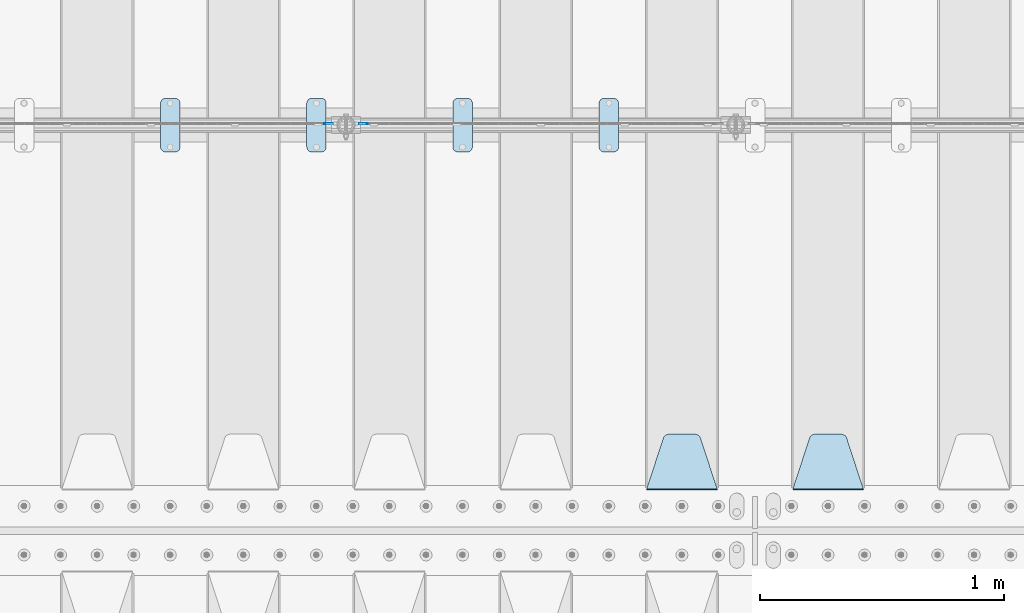
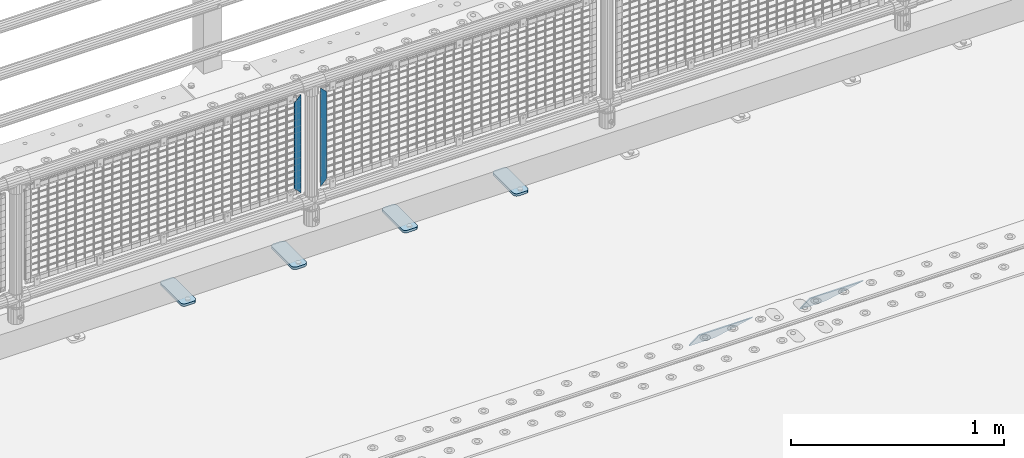
# One storey, part 220 of 257: 8 plates.
"""IFC2X3 building model written with IfcOpenShell, lengths in millimetres."""

from ifc_helpers import new_model, si_unit, frame, origin_with_axes, place, context, subcontext, project, spatial, faceted_brep, material, type_object, element, save


model = new_model("IFC2X3")

# Units and contexts
model_context = context("Model", 3, precision=1e-05, world=origin_with_axes())
body_context = subcontext(model_context, "Body", "Model", "MODEL_VIEW")
ifc_project = project(units=[si_unit("LENGTHUNIT", "METRE", prefix="MILLI"), si_unit("AREAUNIT", "SQUARE_METRE"), si_unit("VOLUMEUNIT", "CUBIC_METRE"), si_unit("MASSUNIT", "GRAM", prefix="KILO"), si_unit("TIMEUNIT", "SECOND"), si_unit("PLANEANGLEUNIT", "RADIAN"), si_unit("SOLIDANGLEUNIT", "STERADIAN"), si_unit("THERMODYNAMICTEMPERATUREUNIT", "DEGREE_CELSIUS"), si_unit("LUMINOUSINTENSITYUNIT", "LUMEN")], contexts=[model_context])

# Site, building, storey
site_placement = place(None, origin_with_axes())
site = spatial("IfcSite", under=ifc_project, at=site_placement, CompositionType="ELEMENT")
building_placement = place(site_placement, origin_with_axes())
building = spatial("IfcBuilding", under=site, at=building_placement, Name="Standard", CompositionType="ELEMENT")
storey_placement = place(building_placement, origin_with_axes())
storey = spatial("IfcBuildingStorey", under=building, at=storey_placement, Name="Undefined", CompositionType="ELEMENT", Elevation=0.0)

# Plates
ifc_material_1 = material(Name="STEEL/S355J2")
plate_type_1 = type_object("IfcPlateType", PredefinedType="NOTDEFINED")
plate_1_placement = place(storey_placement, frame((47310.0, 10774.5, 21.0199999999977), z_axis=(1.0, 0.0, 0.0), x_axis=(0.0, -1.0, 0.0)))
element("IfcPlate", 1, at=plate_1_placement, inside=storey, type_object=plate_type_1, material=ifc_material_1, context=body_context, shape_type="Brep", body=[
    faceted_brep([(0.0, -7.0, 20.0), (0.0, -7.0, 60.0), (0.0, 7.0, 60.0), (0.0, 7.0, 20.0), (0.384294391935327, -7.0, 63.9018064403208), (0.384294391935327, 7.0, 63.9018064403208), (1.52240934977453, -7.0, 67.6536686473046), (1.52240934977453, 7.0, 67.6536686473046), (3.37060775394821, -7.0, 71.1114046603907), (3.37060775394821, 7.0, 71.1114046603907), (5.85786437626848, -7.0, 74.1421356237333), (5.85786437626848, 7.0, 74.1421356237333), (8.88859533960749, -7.0, 76.6293922460536), (8.88859533960749, 7.0, 76.6293922460536), (12.3463313526991, -7.0, 78.4775906502255), (12.3463313526991, 7.0, 78.4775906502255), (16.0981935596774, -7.0, 79.6157056080629), (16.0981935596774, 7.0, 79.6157056080629), (20.0, -7.0, 80.0), (20.0, 7.0, 80.0), (200.0, -7.0, 80.0), (200.0, 7.0, 80.0), (203.901806440323, -7.0, 79.6157056080629), (203.901806440323, 7.0, 79.6157056080629), (207.653668647301, -7.0, 78.4775906502255), (207.653668647301, 7.0, 78.4775906502255), (211.111404660393, -7.0, 76.6293922460536), (211.111404660393, 7.0, 76.6293922460536), (214.142135623732, -7.0, 74.1421356237333), (214.142135623732, 7.0, 74.1421356237333), (216.629392246052, -7.0, 71.1114046603907), (216.629392246052, 7.0, 71.1114046603907), (218.477590650225, -7.0, 67.6536686473046), (218.477590650225, 7.0, 67.6536686473046), (219.615705608065, -7.0, 63.9018064403208), (219.615705608065, 7.0, 63.9018064403208), (220.0, -7.0, 60.0), (220.0, 7.0, 60.0), (220.0, -7.0, 20.0), (220.0, 7.0, 20.0), (219.615705608065, -7.0, 16.0981935596792), (219.615705608065, 7.0, 16.0981935596792), (218.477590650225, -7.0, 12.3463313526954), (218.477590650225, 7.0, 12.3463313526954), (216.629392246052, -7.0, 8.88859533960931), (216.629392246052, 7.0, 8.88859533960931), (214.142135623732, -7.0, 5.85786437626666), (214.142135623732, 7.0, 5.85786437626666), (211.111404660393, -7.0, 3.37060775394639), (211.111404660393, 7.0, 3.37060775394639), (207.653668647301, -7.0, 1.52240934977453), (207.653668647301, 7.0, 1.52240934977453), (203.901806440323, -7.0, 0.384294391937146), (203.901806440323, 7.0, 0.384294391937146), (200.0, -7.0, 0.0), (200.0, 7.0, 0.0), (20.0, -7.0, 0.0), (20.0, 7.0, 0.0), (16.0981935596774, -7.0, 0.384294391937146), (16.0981935596774, 7.0, 0.384294391937146), (12.3463313526991, -7.0, 1.52240934977453), (12.3463313526991, 7.0, 1.52240934977453), (8.88859533960749, -7.0, 3.37060775394639), (8.88859533960749, 7.0, 3.37060775394639), (5.85786437626848, -7.0, 5.85786437626666), (5.85786437626848, 7.0, 5.85786437626666), (3.37060775394821, -7.0, 8.88859533960931), (3.37060775394821, 7.0, 8.88859533960931), (1.52240934977453, -7.0, 12.3463313526954), (1.52240934977453, 7.0, 12.3463313526954), (0.384294391935327, -7.0, 16.0981935596792), (0.384294391935327, 7.0, 16.0981935596792)], [[[0, 1, 2, 3]], [[1, 4, 5, 2]], [[4, 6, 7, 5]], [[6, 8, 9, 7]], [[8, 10, 11, 9]], [[10, 12, 13, 11]], [[12, 14, 15, 13]], [[14, 16, 17, 15]], [[16, 18, 19, 17]], [[18, 20, 21, 19]], [[20, 22, 23, 21]], [[22, 24, 25, 23]], [[24, 26, 27, 25]], [[26, 28, 29, 27]], [[28, 30, 31, 29]], [[30, 32, 33, 31]], [[32, 34, 35, 33]], [[34, 36, 37, 35]], [[36, 38, 39, 37]], [[38, 40, 41, 39]], [[40, 42, 43, 41]], [[42, 44, 45, 43]], [[44, 46, 47, 45]], [[46, 48, 49, 47]], [[48, 50, 51, 49]], [[50, 52, 53, 51]], [[52, 54, 55, 53]], [[54, 56, 57, 55]], [[56, 58, 59, 57]], [[58, 60, 61, 59]], [[60, 62, 63, 61]], [[62, 64, 65, 63]], [[64, 66, 67, 65]], [[66, 68, 69, 67]], [[68, 70, 71, 69]], [[70, 0, 3, 71]], [[5, 7, 9, 11, 13, 15, 17, 19, 21, 23, 25, 27, 29, 31, 33, 35, 37, 39, 41, 43, 45, 47, 49, 51, 53, 55, 57, 59, 61, 63, 65, 67, 69, 71, 3, 2]], [[70, 68, 66, 64, 62, 60, 58, 56, 54, 52, 50, 48, 46, 44, 42, 40, 38, 36, 34, 32, 30, 28, 26, 24, 22, 20, 18, 16, 14, 12, 10, 8, 6, 4, 1, 0]]]),
])
plate_2_placement = place(storey_placement, frame((46710.0, 10774.5, 21.0199999999977), z_axis=(1.0, 0.0, 0.0), x_axis=(0.0, -1.0, 0.0)))
element("IfcPlate", 2, at=plate_2_placement, inside=storey, type_object=plate_type_1, material=ifc_material_1, context=body_context, shape_type="Brep", body=[
    faceted_brep([(0.0, -7.0, 20.0), (0.0, -7.0, 60.0), (0.0, 7.0, 60.0), (0.0, 7.0, 20.0), (0.384294391935327, -7.0, 63.9018064403208), (0.384294391935327, 7.0, 63.9018064403208), (1.52240934977453, -7.0, 67.6536686473046), (1.52240934977453, 7.0, 67.6536686473046), (3.37060775394821, -7.0, 71.1114046603907), (3.37060775394821, 7.0, 71.1114046603907), (5.85786437626848, -7.0, 74.1421356237333), (5.85786437626848, 7.0, 74.1421356237333), (8.88859533960749, -7.0, 76.6293922460536), (8.88859533960749, 7.0, 76.6293922460536), (12.3463313526991, -7.0, 78.4775906502255), (12.3463313526991, 7.0, 78.4775906502255), (16.0981935596774, -7.0, 79.6157056080629), (16.0981935596774, 7.0, 79.6157056080629), (20.0, -7.0, 80.0), (20.0, 7.0, 80.0), (200.0, -7.0, 80.0), (200.0, 7.0, 80.0), (203.901806440323, -7.0, 79.6157056080629), (203.901806440323, 7.0, 79.6157056080629), (207.653668647301, -7.0, 78.4775906502255), (207.653668647301, 7.0, 78.4775906502255), (211.111404660393, -7.0, 76.6293922460536), (211.111404660393, 7.0, 76.6293922460536), (214.142135623732, -7.0, 74.1421356237333), (214.142135623732, 7.0, 74.1421356237333), (216.629392246052, -7.0, 71.1114046603907), (216.629392246052, 7.0, 71.1114046603907), (218.477590650225, -7.0, 67.6536686473046), (218.477590650225, 7.0, 67.6536686473046), (219.615705608065, -7.0, 63.9018064403208), (219.615705608065, 7.0, 63.9018064403208), (220.0, -7.0, 60.0), (220.0, 7.0, 60.0), (220.0, -7.0, 20.0), (220.0, 7.0, 20.0), (219.615705608065, -7.0, 16.0981935596792), (219.615705608065, 7.0, 16.0981935596792), (218.477590650225, -7.0, 12.3463313526954), (218.477590650225, 7.0, 12.3463313526954), (216.629392246052, -7.0, 8.88859533960931), (216.629392246052, 7.0, 8.88859533960931), (214.142135623732, -7.0, 5.85786437626666), (214.142135623732, 7.0, 5.85786437626666), (211.111404660393, -7.0, 3.37060775394639), (211.111404660393, 7.0, 3.37060775394639), (207.653668647301, -7.0, 1.52240934977453), (207.653668647301, 7.0, 1.52240934977453), (203.901806440323, -7.0, 0.384294391937146), (203.901806440323, 7.0, 0.384294391937146), (200.0, -7.0, 0.0), (200.0, 7.0, 0.0), (20.0, -7.0, 0.0), (20.0, 7.0, 0.0), (16.0981935596774, -7.0, 0.384294391937146), (16.0981935596774, 7.0, 0.384294391937146), (12.3463313526991, -7.0, 1.52240934977453), (12.3463313526991, 7.0, 1.52240934977453), (8.88859533960749, -7.0, 3.37060775394639), (8.88859533960749, 7.0, 3.37060775394639), (5.85786437626848, -7.0, 5.85786437626666), (5.85786437626848, 7.0, 5.85786437626666), (3.37060775394821, -7.0, 8.88859533960931), (3.37060775394821, 7.0, 8.88859533960931), (1.52240934977453, -7.0, 12.3463313526954), (1.52240934977453, 7.0, 12.3463313526954), (0.384294391935327, -7.0, 16.0981935596792), (0.384294391935327, 7.0, 16.0981935596792)], [[[0, 1, 2, 3]], [[1, 4, 5, 2]], [[4, 6, 7, 5]], [[6, 8, 9, 7]], [[8, 10, 11, 9]], [[10, 12, 13, 11]], [[12, 14, 15, 13]], [[14, 16, 17, 15]], [[16, 18, 19, 17]], [[18, 20, 21, 19]], [[20, 22, 23, 21]], [[22, 24, 25, 23]], [[24, 26, 27, 25]], [[26, 28, 29, 27]], [[28, 30, 31, 29]], [[30, 32, 33, 31]], [[32, 34, 35, 33]], [[34, 36, 37, 35]], [[36, 38, 39, 37]], [[38, 40, 41, 39]], [[40, 42, 43, 41]], [[42, 44, 45, 43]], [[44, 46, 47, 45]], [[46, 48, 49, 47]], [[48, 50, 51, 49]], [[50, 52, 53, 51]], [[52, 54, 55, 53]], [[54, 56, 57, 55]], [[56, 58, 59, 57]], [[58, 60, 61, 59]], [[60, 62, 63, 61]], [[62, 64, 65, 63]], [[64, 66, 67, 65]], [[66, 68, 69, 67]], [[68, 70, 71, 69]], [[70, 0, 3, 71]], [[5, 7, 9, 11, 13, 15, 17, 19, 21, 23, 25, 27, 29, 31, 33, 35, 37, 39, 41, 43, 45, 47, 49, 51, 53, 55, 57, 59, 61, 63, 65, 67, 69, 71, 3, 2]], [[70, 68, 66, 64, 62, 60, 58, 56, 54, 52, 50, 48, 46, 44, 42, 40, 38, 36, 34, 32, 30, 28, 26, 24, 22, 20, 18, 16, 14, 12, 10, 8, 6, 4, 1, 0]]]),
])
plate_3_placement = place(storey_placement, frame((46110.0, 10774.5, 21.0199999999977), z_axis=(1.0, 0.0, 0.0), x_axis=(0.0, -1.0, 0.0)))
element("IfcPlate", 3, at=plate_3_placement, inside=storey, type_object=plate_type_1, material=ifc_material_1, context=body_context, shape_type="Brep", body=[
    faceted_brep([(0.0, -7.0, 20.0), (0.0, -7.0, 60.0), (0.0, 7.0, 60.0), (0.0, 7.0, 20.0), (0.384294391935327, -7.0, 63.9018064403208), (0.384294391935327, 7.0, 63.9018064403208), (1.52240934977453, -7.0, 67.6536686473046), (1.52240934977453, 7.0, 67.6536686473046), (3.37060775394821, -7.0, 71.1114046603907), (3.37060775394821, 7.0, 71.1114046603907), (5.85786437626848, -7.0, 74.1421356237333), (5.85786437626848, 7.0, 74.1421356237333), (8.88859533960749, -7.0, 76.6293922460536), (8.88859533960749, 7.0, 76.6293922460536), (12.3463313526991, -7.0, 78.4775906502255), (12.3463313526991, 7.0, 78.4775906502255), (16.0981935596774, -7.0, 79.6157056080629), (16.0981935596774, 7.0, 79.6157056080629), (20.0, -7.0, 80.0), (20.0, 7.0, 80.0), (200.0, -7.0, 80.0), (200.0, 7.0, 80.0), (203.901806440323, -7.0, 79.6157056080629), (203.901806440323, 7.0, 79.6157056080629), (207.653668647301, -7.0, 78.4775906502255), (207.653668647301, 7.0, 78.4775906502255), (211.111404660393, -7.0, 76.6293922460536), (211.111404660393, 7.0, 76.6293922460536), (214.142135623732, -7.0, 74.1421356237333), (214.142135623732, 7.0, 74.1421356237333), (216.629392246052, -7.0, 71.1114046603907), (216.629392246052, 7.0, 71.1114046603907), (218.477590650225, -7.0, 67.6536686473046), (218.477590650225, 7.0, 67.6536686473046), (219.615705608065, -7.0, 63.9018064403208), (219.615705608065, 7.0, 63.9018064403208), (220.0, -7.0, 60.0), (220.0, 7.0, 60.0), (220.0, -7.0, 20.0), (220.0, 7.0, 20.0), (219.615705608065, -7.0, 16.0981935596792), (219.615705608065, 7.0, 16.0981935596792), (218.477590650225, -7.0, 12.3463313526954), (218.477590650225, 7.0, 12.3463313526954), (216.629392246052, -7.0, 8.88859533960931), (216.629392246052, 7.0, 8.88859533960931), (214.142135623732, -7.0, 5.85786437626666), (214.142135623732, 7.0, 5.85786437626666), (211.111404660393, -7.0, 3.37060775394639), (211.111404660393, 7.0, 3.37060775394639), (207.653668647301, -7.0, 1.52240934977453), (207.653668647301, 7.0, 1.52240934977453), (203.901806440323, -7.0, 0.384294391937146), (203.901806440323, 7.0, 0.384294391937146), (200.0, -7.0, 0.0), (200.0, 7.0, 0.0), (20.0, -7.0, 0.0), (20.0, 7.0, 0.0), (16.0981935596774, -7.0, 0.384294391937146), (16.0981935596774, 7.0, 0.384294391937146), (12.3463313526991, -7.0, 1.52240934977453), (12.3463313526991, 7.0, 1.52240934977453), (8.88859533960749, -7.0, 3.37060775394639), (8.88859533960749, 7.0, 3.37060775394639), (5.85786437626848, -7.0, 5.85786437626666), (5.85786437626848, 7.0, 5.85786437626666), (3.37060775394821, -7.0, 8.88859533960931), (3.37060775394821, 7.0, 8.88859533960931), (1.52240934977453, -7.0, 12.3463313526954), (1.52240934977453, 7.0, 12.3463313526954), (0.384294391935327, -7.0, 16.0981935596792), (0.384294391935327, 7.0, 16.0981935596792)], [[[0, 1, 2, 3]], [[1, 4, 5, 2]], [[4, 6, 7, 5]], [[6, 8, 9, 7]], [[8, 10, 11, 9]], [[10, 12, 13, 11]], [[12, 14, 15, 13]], [[14, 16, 17, 15]], [[16, 18, 19, 17]], [[18, 20, 21, 19]], [[20, 22, 23, 21]], [[22, 24, 25, 23]], [[24, 26, 27, 25]], [[26, 28, 29, 27]], [[28, 30, 31, 29]], [[30, 32, 33, 31]], [[32, 34, 35, 33]], [[34, 36, 37, 35]], [[36, 38, 39, 37]], [[38, 40, 41, 39]], [[40, 42, 43, 41]], [[42, 44, 45, 43]], [[44, 46, 47, 45]], [[46, 48, 49, 47]], [[48, 50, 51, 49]], [[50, 52, 53, 51]], [[52, 54, 55, 53]], [[54, 56, 57, 55]], [[56, 58, 59, 57]], [[58, 60, 61, 59]], [[60, 62, 63, 61]], [[62, 64, 65, 63]], [[64, 66, 67, 65]], [[66, 68, 69, 67]], [[68, 70, 71, 69]], [[70, 0, 3, 71]], [[5, 7, 9, 11, 13, 15, 17, 19, 21, 23, 25, 27, 29, 31, 33, 35, 37, 39, 41, 43, 45, 47, 49, 51, 53, 55, 57, 59, 61, 63, 65, 67, 69, 71, 3, 2]], [[70, 68, 66, 64, 62, 60, 58, 56, 54, 52, 50, 48, 46, 44, 42, 40, 38, 36, 34, 32, 30, 28, 26, 24, 22, 20, 18, 16, 14, 12, 10, 8, 6, 4, 1, 0]]]),
])
plate_4_placement = place(storey_placement, frame((45510.0, 10774.5, 21.0199999999977), z_axis=(1.0, 0.0, 0.0), x_axis=(0.0, -1.0, 0.0)))
element("IfcPlate", 4, at=plate_4_placement, inside=storey, type_object=plate_type_1, material=ifc_material_1, context=body_context, shape_type="Brep", body=[
    faceted_brep([(0.0, -7.0, 20.0), (0.0, -7.0, 60.0), (0.0, 7.0, 60.0), (0.0, 7.0, 20.0), (0.384294391935327, -7.0, 63.9018064403208), (0.384294391935327, 7.0, 63.9018064403208), (1.52240934977453, -7.0, 67.6536686473046), (1.52240934977453, 7.0, 67.6536686473046), (3.37060775394821, -7.0, 71.1114046603907), (3.37060775394821, 7.0, 71.1114046603907), (5.85786437626848, -7.0, 74.1421356237333), (5.85786437626848, 7.0, 74.1421356237333), (8.88859533960749, -7.0, 76.6293922460536), (8.88859533960749, 7.0, 76.6293922460536), (12.3463313526991, -7.0, 78.4775906502255), (12.3463313526991, 7.0, 78.4775906502255), (16.0981935596774, -7.0, 79.6157056080629), (16.0981935596774, 7.0, 79.6157056080629), (20.0, -7.0, 80.0), (20.0, 7.0, 80.0), (200.0, -7.0, 80.0), (200.0, 7.0, 80.0), (203.901806440323, -7.0, 79.6157056080629), (203.901806440323, 7.0, 79.6157056080629), (207.653668647301, -7.0, 78.4775906502255), (207.653668647301, 7.0, 78.4775906502255), (211.111404660393, -7.0, 76.6293922460536), (211.111404660393, 7.0, 76.6293922460536), (214.142135623732, -7.0, 74.1421356237333), (214.142135623732, 7.0, 74.1421356237333), (216.629392246052, -7.0, 71.1114046603907), (216.629392246052, 7.0, 71.1114046603907), (218.477590650225, -7.0, 67.6536686473046), (218.477590650225, 7.0, 67.6536686473046), (219.615705608065, -7.0, 63.9018064403208), (219.615705608065, 7.0, 63.9018064403208), (220.0, -7.0, 60.0), (220.0, 7.0, 60.0), (220.0, -7.0, 20.0), (220.0, 7.0, 20.0), (219.615705608065, -7.0, 16.0981935596792), (219.615705608065, 7.0, 16.0981935596792), (218.477590650225, -7.0, 12.3463313526954), (218.477590650225, 7.0, 12.3463313526954), (216.629392246052, -7.0, 8.88859533960931), (216.629392246052, 7.0, 8.88859533960931), (214.142135623732, -7.0, 5.85786437626666), (214.142135623732, 7.0, 5.85786437626666), (211.111404660393, -7.0, 3.37060775394639), (211.111404660393, 7.0, 3.37060775394639), (207.653668647301, -7.0, 1.52240934977453), (207.653668647301, 7.0, 1.52240934977453), (203.901806440323, -7.0, 0.384294391937146), (203.901806440323, 7.0, 0.384294391937146), (200.0, -7.0, 0.0), (200.0, 7.0, 0.0), (20.0, -7.0, 0.0), (20.0, 7.0, 0.0), (16.0981935596774, -7.0, 0.384294391937146), (16.0981935596774, 7.0, 0.384294391937146), (12.3463313526991, -7.0, 1.52240934977453), (12.3463313526991, 7.0, 1.52240934977453), (8.88859533960749, -7.0, 3.37060775394639), (8.88859533960749, 7.0, 3.37060775394639), (5.85786437626848, -7.0, 5.85786437626666), (5.85786437626848, 7.0, 5.85786437626666), (3.37060775394821, -7.0, 8.88859533960931), (3.37060775394821, 7.0, 8.88859533960931), (1.52240934977453, -7.0, 12.3463313526954), (1.52240934977453, 7.0, 12.3463313526954), (0.384294391935327, -7.0, 16.0981935596792), (0.384294391935327, 7.0, 16.0981935596792)], [[[0, 1, 2, 3]], [[1, 4, 5, 2]], [[4, 6, 7, 5]], [[6, 8, 9, 7]], [[8, 10, 11, 9]], [[10, 12, 13, 11]], [[12, 14, 15, 13]], [[14, 16, 17, 15]], [[16, 18, 19, 17]], [[18, 20, 21, 19]], [[20, 22, 23, 21]], [[22, 24, 25, 23]], [[24, 26, 27, 25]], [[26, 28, 29, 27]], [[28, 30, 31, 29]], [[30, 32, 33, 31]], [[32, 34, 35, 33]], [[34, 36, 37, 35]], [[36, 38, 39, 37]], [[38, 40, 41, 39]], [[40, 42, 43, 41]], [[42, 44, 45, 43]], [[44, 46, 47, 45]], [[46, 48, 49, 47]], [[48, 50, 51, 49]], [[50, 52, 53, 51]], [[52, 54, 55, 53]], [[54, 56, 57, 55]], [[56, 58, 59, 57]], [[58, 60, 61, 59]], [[60, 62, 63, 61]], [[62, 64, 65, 63]], [[64, 66, 67, 65]], [[66, 68, 69, 67]], [[68, 70, 71, 69]], [[70, 0, 3, 71]], [[5, 7, 9, 11, 13, 15, 17, 19, 21, 23, 25, 27, 29, 31, 33, 35, 37, 39, 41, 43, 45, 47, 49, 51, 53, 55, 57, 59, 61, 63, 65, 67, 69, 71, 3, 2]], [[70, 68, 66, 64, 62, 60, 58, 56, 54, 52, 50, 48, 46, 44, 42, 40, 38, 36, 34, 32, 30, 28, 26, 24, 22, 20, 18, 16, 14, 12, 10, 8, 6, 4, 1, 0]]]),
])
ifc_material_2 = material(Name="STEEL/S355N")
plate_type_2 = type_object("IfcPlateType", PredefinedType="NOTDEFINED")
plate_5_placement = place(storey_placement, frame((48395.0, 9168.23223304703, -1.76776695296758), z_axis=(0.0, 0.707106781186547, -0.707106781186548), x_axis=(-1.0, 0.0, 0.0)))
element("IfcPlate", 5, at=plate_5_placement, inside=storey, type_object=plate_type_2, material=ifc_material_2, context=body_context, shape_type="Brep", body=[
    faceted_brep([(0.0, -2.5, 0.0), (69.345504679477, -2.50000000000091, 300.17173142483), (69.345504679477, 2.5, 300.171731424831), (0.0, 2.5, 0.0), (70.927406119954, -2.50000000000091, 304.8974424154), (70.927406119954, 2.5, 304.8974424154), (73.3818627772271, -2.50000000000091, 309.234538108527), (73.3818627772271, 2.49999999999909, 309.234538108527), (76.6187032999587, -2.5, 313.023683126103), (76.6187032999587, 2.5, 313.023683126103), (80.5190132705029, -2.5, 316.125672595372), (80.5190132705029, 2.5, 316.125672595371), (84.9395038596849, -2.5, 318.426546230476), (84.9395038596849, 2.5, 318.426546230477), (89.7177759439219, -2.5, 319.841774983275), (89.7177759439219, 2.5, 319.841774983275), (94.6782862926484, -2.5, 320.319366455079), (94.6782862926484, 2.5, 320.319366455079), (195.321713707352, -2.5, 320.319366455079), (195.321713707352, 2.5, 320.319366455079), (200.282224056078, -2.5, 319.841774983275), (200.282224056078, 2.49999999999909, 319.841774983275), (205.060496140315, -2.5, 318.426546230476), (205.060496140315, 2.49999999999909, 318.426546230475), (209.480986729497, -2.5, 316.125672595371), (209.480986729497, 2.5, 316.125672595371), (213.381296700041, -2.50000000000091, 313.023683126102), (213.381296700041, 2.5, 313.023683126103), (216.618137222766, -2.50000000000091, 309.234538108527), (216.618137222766, 2.5, 309.234538108527), (219.072593880039, -2.5, 304.897442415399), (219.072593880039, 2.5, 304.897442415399), (220.654495320523, -2.50000000000091, 300.17173142483), (220.654495320523, 2.5, 300.171731424831), (290.0, -2.50000000000091, 0.0), (290.0, 2.5, 9.09494701772928e-13)], [[[0, 1, 2, 3]], [[1, 4, 5, 2]], [[4, 6, 7, 5]], [[6, 8, 9, 7]], [[8, 10, 11, 9]], [[10, 12, 13, 11]], [[12, 14, 15, 13]], [[14, 16, 17, 15]], [[16, 18, 19, 17]], [[18, 20, 21, 19]], [[20, 22, 23, 21]], [[22, 24, 25, 23]], [[24, 26, 27, 25]], [[26, 28, 29, 27]], [[28, 30, 31, 29]], [[30, 32, 33, 31]], [[32, 34, 35, 33]], [[34, 0, 3, 35]], [[5, 7, 9, 11, 13, 15, 17, 19, 21, 23, 25, 27, 29, 31, 33, 35, 3, 2]], [[34, 32, 30, 28, 26, 24, 22, 20, 18, 16, 14, 12, 10, 8, 6, 4, 1, 0]]]),
])
plate_6_placement = place(storey_placement, frame((47795.0, 9168.23223304703, -1.76776695296758), z_axis=(0.0, 0.707106781186547, -0.707106781186548), x_axis=(-1.0, 0.0, 0.0)))
element("IfcPlate", 6, at=plate_6_placement, inside=storey, type_object=plate_type_2, material=ifc_material_2, context=body_context, shape_type="Brep", body=[
    faceted_brep([(0.0, -2.5, 0.0), (69.345504679477, -2.50000000000091, 300.17173142483), (69.345504679477, 2.5, 300.171731424831), (0.0, 2.5, 0.0), (70.927406119954, -2.50000000000091, 304.8974424154), (70.927406119954, 2.5, 304.8974424154), (73.3818627772271, -2.50000000000091, 309.234538108527), (73.3818627772271, 2.49999999999909, 309.234538108527), (76.6187032999587, -2.5, 313.023683126103), (76.6187032999587, 2.5, 313.023683126103), (80.5190132705029, -2.5, 316.125672595372), (80.5190132705029, 2.5, 316.125672595371), (84.9395038596849, -2.5, 318.426546230476), (84.9395038596849, 2.5, 318.426546230477), (89.7177759439219, -2.5, 319.841774983275), (89.7177759439219, 2.5, 319.841774983275), (94.6782862926484, -2.5, 320.319366455079), (94.6782862926484, 2.5, 320.319366455079), (195.321713707352, -2.5, 320.319366455079), (195.321713707352, 2.5, 320.319366455079), (200.282224056078, -2.5, 319.841774983275), (200.282224056078, 2.49999999999909, 319.841774983275), (205.060496140315, -2.5, 318.426546230476), (205.060496140315, 2.49999999999909, 318.426546230475), (209.480986729497, -2.5, 316.125672595371), (209.480986729497, 2.5, 316.125672595371), (213.381296700041, -2.50000000000091, 313.023683126102), (213.381296700041, 2.5, 313.023683126103), (216.618137222766, -2.50000000000091, 309.234538108527), (216.618137222766, 2.5, 309.234538108527), (219.072593880039, -2.5, 304.897442415399), (219.072593880039, 2.5, 304.897442415399), (220.654495320523, -2.50000000000091, 300.17173142483), (220.654495320523, 2.5, 300.171731424831), (290.0, -2.50000000000091, 0.0), (290.0, 2.5, 9.09494701772928e-13)], [[[0, 1, 2, 3]], [[1, 4, 5, 2]], [[4, 6, 7, 5]], [[6, 8, 9, 7]], [[8, 10, 11, 9]], [[10, 12, 13, 11]], [[12, 14, 15, 13]], [[14, 16, 17, 15]], [[16, 18, 19, 17]], [[18, 20, 21, 19]], [[20, 22, 23, 21]], [[22, 24, 25, 23]], [[24, 26, 27, 25]], [[26, 28, 29, 27]], [[28, 30, 31, 29]], [[30, 32, 33, 31]], [[32, 34, 35, 33]], [[34, 0, 3, 35]], [[5, 7, 9, 11, 13, 15, 17, 19, 21, 23, 25, 27, 29, 31, 33, 35, 3, 2]], [[34, 32, 30, 28, 26, 24, 22, 20, 18, 16, 14, 12, 10, 8, 6, 4, 1, 0]]]),
])
ifc_material_3 = material(Name="Misc_Undefined")
plate_type_3 = type_object("IfcPlateType", PredefinedType="NOTDEFINED")
plate_7_placement = place(storey_placement, frame((46359.509713541, 10670.5, 879.519963133601), z_axis=(-0.707008801899317, 0.0, -0.707204746899292), x_axis=(-0.707204746899293, 0.0, 0.707008801899317)))
element("IfcPlate", 7, at=plate_7_placement, inside=storey, type_object=plate_type_3, material=ifc_material_3, context=body_context, shape_type="Brep", body=[
    faceted_brep([(0.0, -1.5, -5.6843418860808e-14), (-348.552185058586, -1.5, 348.655029296868), (-348.552185058586, 1.5, 348.655029296868), (0.0, 1.5, -5.6843418860808e-14), (-348.544891357407, -1.5, 398.152496337891), (-348.544891357407, 1.5, 398.152496337891), (49.5043945312573, -1.5, 7.27595761418343e-11), (49.5043945312573, 1.5, 7.27595761418343e-11)], [[[0, 1, 2, 3]], [[1, 4, 5, 2]], [[4, 6, 7, 5]], [[6, 0, 3, 7]], [[5, 7, 3, 2]], [[6, 4, 1, 0]]]),
])
plate_8_placement = place(storey_placement, frame((46182.4996874836, 10670.5, 879.52), z_axis=(0.707103624179501, 0.0, -0.707109938179499), x_axis=(0.707109938179525, 0.0, 0.707103624179475)))
element("IfcPlate", 8, at=plate_8_placement, inside=storey, type_object=plate_type_3, material=ifc_material_3, context=body_context, shape_type="Brep", body=[
    faceted_brep([(0.0, -1.5, -5.6843418860808e-14), (-348.605163574226, -1.5, 348.602081298828), (-348.605163574226, 1.5, 348.602081298828), (0.0, 1.5, -5.6843418860808e-14), (-348.605163574226, -1.5, 398.099334716804), (-348.605163574226, 1.5, 398.099334716804), (49.4976959228443, -1.5, 6.54836185276508e-11), (49.4976959228443, 1.5, 6.54836185276508e-11)], [[[0, 1, 2, 3]], [[1, 4, 5, 2]], [[4, 6, 7, 5]], [[6, 0, 3, 7]], [[5, 7, 3, 2]], [[6, 4, 1, 0]]]),
])

save(model, "model.ifc")
